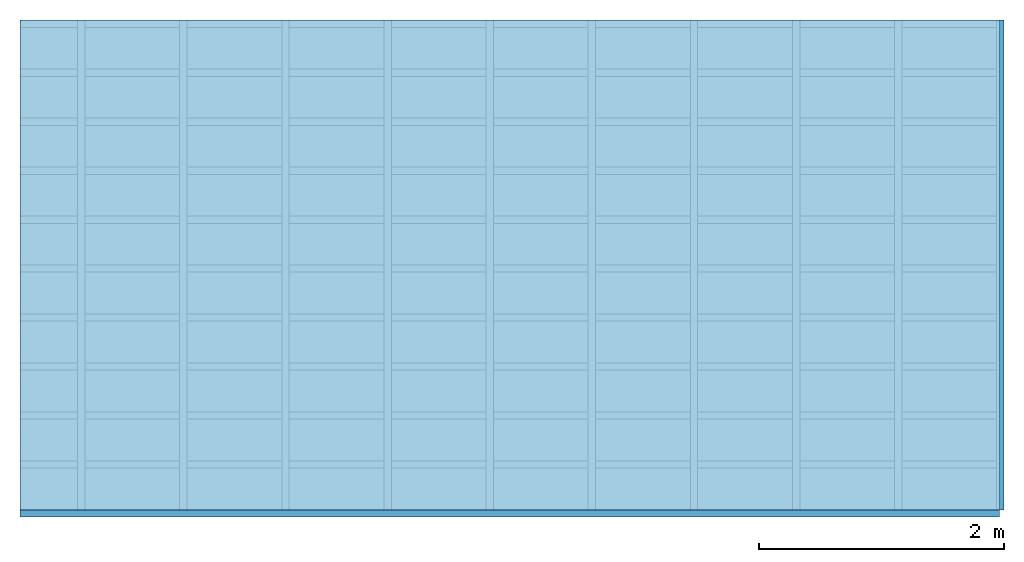
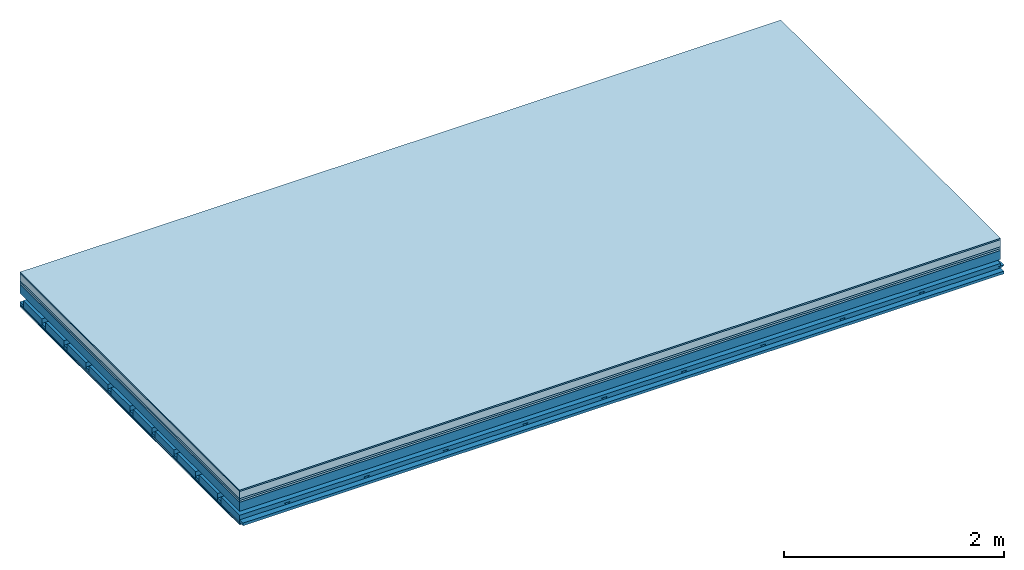
# One storey: 7 plates, 4 members, 1 element without a shape of its own.
"""IFC4 building model written with IfcOpenShell, lengths in metres."""

from ifc_helpers import new_model, si_unit, derived_unit, direction, frame, frame_2d, origin, origin_with_axes, place, context, project, spatial, polyline, rectangle, outline, extrude, material, layer, layer_set, type_object, element, aggregate, save


model = new_model("IFC4")

# Units and contexts
plan_context = context("Plan", 3, precision=1e-05, world=origin(), true_north=direction((0.0, 1.0)))
model_context = context("Model", 3, precision=1e-05, world=origin(), true_north=direction((0.0, 1.0)))
ifc_project = project(units=[si_unit("LENGTHUNIT", "METRE"), derived_unit("SOUNDPRESSUREUNIT", [(si_unit("PRESSUREUNIT", "PASCAL", prefix="MICRO"), 0)]), si_unit("ENERGYUNIT", "JOULE", prefix="MEGA"), si_unit("MASSUNIT", "GRAM", prefix="KILO"), derived_unit("THERMALTRANSMITTANCEUNIT", [(si_unit("POWERUNIT", "WATT"), 1), (si_unit("AREAUNIT", "SQUARE_METRE"), -1), (si_unit("THERMODYNAMICTEMPERATUREUNIT", "KELVIN"), -1)]), derived_unit("AREADENSITYUNIT", [(si_unit("MASSUNIT", "GRAM", prefix="KILO"), 1), (si_unit("AREAUNIT", "SQUARE_METRE"), -1)]), derived_unit("USERDEFINED", [(si_unit("ENERGYUNIT", "JOULE", prefix="MEGA"), 1), (si_unit("AREAUNIT", "SQUARE_METRE"), -1)])], contexts=[plan_context, model_context])

# Site, building, storey
site = spatial("IfcSite", under=ifc_project)
building_placement = place(None, origin())
building = spatial("IfcBuilding", under=site, at=building_placement)
storey_placement = place(building_placement, origin())
storey = spatial("IfcBuildingStorey", under=building, at=storey_placement)

# Slab, members, plates
ifc_material_1 = material(Category="11.013")
ifc_layer_1 = layer(ifc_material_1, 0.015, Name="Flooring")
ifc_material_2 = material(Name="Cement screed", Category="04.006")
ifc_layer_2 = layer(ifc_material_2, 0.08, Name="On-material")
ifc_material_3 = material(Name="Wood fiber generic product", Category="10.009")
ifc_layer_3 = layer(ifc_material_3, 0.02, Name="Impact sound insulation")
ifc_material_4 = material(Category="10.004")
ifc_layer_4 = layer(ifc_material_4, 0.02, Name="Additional insulation")
ifc_material_5 = material(Name="no composite action")
ifc_layer_5 = layer(ifc_material_5, 0.0, Name="Bond")
ifc_layer_6 = layer(None, 0.1, Name="Supporting structure")
ifc_layer_7 = layer(ifc_material_5, 0.0, Name="Bond")
ifc_layer_8 = layer(None, 0.095, Name="Coupling")
ifc_layer_9 = layer(None, 0.03, Name="Battens / profiles")
ifc_material_6 = material(Name="Plasterboard type A", Category="03.008")
ifc_layer_10 = layer(ifc_material_6, 0.0125, Name="Ceiling covering 1st layer")
ifc_layer_11 = layer(ifc_material_6, 0.0125, Name="Ceiling covering layer 2")
ifc_material_7 = material(Category="04.001")
ifc_layer_12 = layer(ifc_material_7, 0.003, Name="Surface / treatment")
ifc_layer_set = layer_set([ifc_layer_1, ifc_layer_2, ifc_layer_3, ifc_layer_4, ifc_layer_5, ifc_layer_6, ifc_layer_7, ifc_layer_8, ifc_layer_9, ifc_layer_10, ifc_layer_11, ifc_layer_12])
slab_type = type_object("IfcSlabType", Name="A2149", PredefinedType="NOTDEFINED", material=ifc_layer_set)
slab_placement = place(None, frame((0.0, 0.0, 0.0), z_axis=(0.0, 0.0, -1.0), x_axis=(1.0, 0.0, 0.0)))
slab = element("IfcSlab", 1, at=slab_placement, inside=storey, type_object=slab_type, material=ifc_layer_set, Name="Slab #1")
ifc_material_8 = material(Name="Solid timber panel")
member_1_placement = place(slab_placement, origin())
member_1 = element("IfcMember", 2, at=member_1_placement, material=ifc_material_8, Name="Supporting structure", context=plan_context, shape_type="SweptSolid", body=[
    extrude(rectangle(XDim=1.0, YDim=0.1, at=frame_2d((0.5, 0.05), x_axis=(1.0, 0.0))), frame((0.0, 4.0, 0.135), z_axis=(0.0, -1.0, 0.0), x_axis=(1.0, 0.0, 0.0)), (0.0, 0.0, 1.0), 4.0),
    extrude(rectangle(XDim=1.0, YDim=0.1, at=frame_2d((0.5, 0.05), x_axis=(1.0, 0.0))), frame((1.0, 4.0, 0.135), z_axis=(0.0, -1.0, 0.0), x_axis=(1.0, 0.0, 0.0)), (0.0, 0.0, 1.0), 4.0),
    extrude(rectangle(XDim=1.0, YDim=0.1, at=frame_2d((0.5, 0.05), x_axis=(1.0, 0.0))), frame((2.0, 4.0, 0.135), z_axis=(0.0, -1.0, 0.0), x_axis=(1.0, 0.0, 0.0)), (0.0, 0.0, 1.0), 4.0),
    extrude(rectangle(XDim=1.0, YDim=0.1, at=frame_2d((0.5, 0.05), x_axis=(1.0, 0.0))), frame((3.0, 4.0, 0.135), z_axis=(0.0, -1.0, 0.0), x_axis=(1.0, 0.0, 0.0)), (0.0, 0.0, 1.0), 4.0),
    extrude(rectangle(XDim=1.0, YDim=0.1, at=frame_2d((0.5, 0.05), x_axis=(1.0, 0.0))), frame((4.0, 4.0, 0.135), z_axis=(0.0, -1.0, 0.0), x_axis=(1.0, 0.0, 0.0)), (0.0, 0.0, 1.0), 4.0),
    extrude(rectangle(XDim=1.0, YDim=0.1, at=frame_2d((0.5, 0.05), x_axis=(1.0, 0.0))), frame((5.0, 4.0, 0.135), z_axis=(0.0, -1.0, 0.0), x_axis=(1.0, 0.0, 0.0)), (0.0, 0.0, 1.0), 4.0),
    extrude(rectangle(XDim=1.0, YDim=0.1, at=frame_2d((0.5, 0.05), x_axis=(1.0, 0.0))), frame((6.0, 4.0, 0.135), z_axis=(0.0, -1.0, 0.0), x_axis=(1.0, 0.0, 0.0)), (0.0, 0.0, 1.0), 4.0),
    extrude(rectangle(XDim=1.0, YDim=0.1, at=frame_2d((0.5, 0.05), x_axis=(1.0, 0.0))), frame((7.0, 4.0, 0.135), z_axis=(0.0, -1.0, 0.0), x_axis=(1.0, 0.0, 0.0)), (0.0, 0.0, 1.0), 4.0),
])
ifc_material_9 = material()
member_2_placement = place(slab_placement, origin())
member_2 = element("IfcMember", 3, at=member_2_placement, material=ifc_material_9, Name="Coupling", context=plan_context, shape_type="SweptSolid", body=[
    extrude(outline(polyline([(0.0, 0.0), (0.06, 0.0), (0.04, 0.02), (0.02, 0.02), (0.0, 0.0)])), frame((0.47, 4.0, 0.31), z_axis=(0.0, -1.0, 0.0), x_axis=(1.0, 0.0, 0.0)), (0.0, 0.0, 1.0), 4.0),
    extrude(outline(polyline([(0.0, 0.0), (0.06, 0.0), (0.04, 0.02), (0.02, 0.02), (0.0, 0.0)])), frame((1.304, 4.0, 0.31), z_axis=(0.0, -1.0, 0.0), x_axis=(1.0, 0.0, 0.0)), (0.0, 0.0, 1.0), 4.0),
    extrude(outline(polyline([(0.0, 0.0), (0.06, 0.0), (0.04, 0.02), (0.02, 0.02), (0.0, 0.0)])), frame((2.138, 4.0, 0.31), z_axis=(0.0, -1.0, 0.0), x_axis=(1.0, 0.0, 0.0)), (0.0, 0.0, 1.0), 4.0),
    extrude(outline(polyline([(0.0, 0.0), (0.06, 0.0), (0.04, 0.02), (0.02, 0.02), (0.0, 0.0)])), frame((2.972, 4.0, 0.31), z_axis=(0.0, -1.0, 0.0), x_axis=(1.0, 0.0, 0.0)), (0.0, 0.0, 1.0), 4.0),
    extrude(outline(polyline([(0.0, 0.0), (0.06, 0.0), (0.04, 0.02), (0.02, 0.02), (0.0, 0.0)])), frame((3.806, 4.0, 0.31), z_axis=(0.0, -1.0, 0.0), x_axis=(1.0, 0.0, 0.0)), (0.0, 0.0, 1.0), 4.0),
    extrude(outline(polyline([(0.0, 0.0), (0.06, 0.0), (0.04, 0.02), (0.02, 0.02), (0.0, 0.0)])), frame((4.64, 4.0, 0.31), z_axis=(0.0, -1.0, 0.0), x_axis=(1.0, 0.0, 0.0)), (0.0, 0.0, 1.0), 4.0),
    extrude(outline(polyline([(0.0, 0.0), (0.06, 0.0), (0.04, 0.02), (0.02, 0.02), (0.0, 0.0)])), frame((5.474, 4.0, 0.31), z_axis=(0.0, -1.0, 0.0), x_axis=(1.0, 0.0, 0.0)), (0.0, 0.0, 1.0), 4.0),
    extrude(outline(polyline([(0.0, 0.0), (0.06, 0.0), (0.04, 0.02), (0.02, 0.02), (0.0, 0.0)])), frame((6.308, 4.0, 0.31), z_axis=(0.0, -1.0, 0.0), x_axis=(1.0, 0.0, 0.0)), (0.0, 0.0, 1.0), 4.0),
    extrude(outline(polyline([(0.0, 0.0), (0.06, 0.0), (0.04, 0.02), (0.02, 0.02), (0.0, 0.0)])), frame((7.142, 4.0, 0.31), z_axis=(0.0, -1.0, 0.0), x_axis=(1.0, 0.0, 0.0)), (0.0, 0.0, 1.0), 4.0),
    extrude(outline(polyline([(0.0, 0.0), (0.06, 0.0), (0.04, 0.02), (0.02, 0.02), (0.0, 0.0)])), frame((7.976, 4.0, 0.31), z_axis=(0.0, -1.0, 0.0), x_axis=(1.0, 0.0, 0.0)), (0.0, 0.0, 1.0), 4.0),
])
member_3_placement = place(slab_placement, origin())
member_3 = element("IfcMember", 4, at=member_3_placement, material=ifc_material_9, Name="Battens / profiles", context=plan_context, shape_type="SweptSolid", body=[
    extrude(rectangle(XDim=0.06, YDim=0.03, at=frame_2d((0.03, 0.015), x_axis=(1.0, 0.0))), frame((0.0, 0.0, 0.33), z_axis=(1.0, 0.0, 0.0), x_axis=(0.0, 1.0, 0.0)), (0.0, 0.0, 1.0), 8.0),
    extrude(rectangle(XDim=0.06, YDim=0.03, at=frame_2d((0.03, 0.015), x_axis=(1.0, 0.0))), frame((0.0, 0.4, 0.33), z_axis=(1.0, 0.0, 0.0), x_axis=(0.0, 1.0, 0.0)), (0.0, 0.0, 1.0), 8.0),
    extrude(rectangle(XDim=0.06, YDim=0.03, at=frame_2d((0.03, 0.015), x_axis=(1.0, 0.0))), frame((0.0, 0.8, 0.33), z_axis=(1.0, 0.0, 0.0), x_axis=(0.0, 1.0, 0.0)), (0.0, 0.0, 1.0), 8.0),
    extrude(rectangle(XDim=0.06, YDim=0.03, at=frame_2d((0.03, 0.015), x_axis=(1.0, 0.0))), frame((0.0, 1.2, 0.33), z_axis=(1.0, 0.0, 0.0), x_axis=(0.0, 1.0, 0.0)), (0.0, 0.0, 1.0), 8.0),
    extrude(rectangle(XDim=0.06, YDim=0.03, at=frame_2d((0.03, 0.015), x_axis=(1.0, 0.0))), frame((0.0, 1.6, 0.33), z_axis=(1.0, 0.0, 0.0), x_axis=(0.0, 1.0, 0.0)), (0.0, 0.0, 1.0), 8.0),
    extrude(rectangle(XDim=0.06, YDim=0.03, at=frame_2d((0.03, 0.015), x_axis=(1.0, 0.0))), frame((0.0, 2.0, 0.33), z_axis=(1.0, 0.0, 0.0), x_axis=(0.0, 1.0, 0.0)), (0.0, 0.0, 1.0), 8.0),
    extrude(rectangle(XDim=0.06, YDim=0.03, at=frame_2d((0.03, 0.015), x_axis=(1.0, 0.0))), frame((0.0, 2.4, 0.33), z_axis=(1.0, 0.0, 0.0), x_axis=(0.0, 1.0, 0.0)), (0.0, 0.0, 1.0), 8.0),
    extrude(rectangle(XDim=0.06, YDim=0.03, at=frame_2d((0.03, 0.015), x_axis=(1.0, 0.0))), frame((0.0, 2.8, 0.33), z_axis=(1.0, 0.0, 0.0), x_axis=(0.0, 1.0, 0.0)), (0.0, 0.0, 1.0), 8.0),
    extrude(rectangle(XDim=0.06, YDim=0.03, at=frame_2d((0.03, 0.015), x_axis=(1.0, 0.0))), frame((0.0, 3.2, 0.33), z_axis=(1.0, 0.0, 0.0), x_axis=(0.0, 1.0, 0.0)), (0.0, 0.0, 1.0), 8.0),
    extrude(rectangle(XDim=0.06, YDim=0.03, at=frame_2d((0.03, 0.015), x_axis=(1.0, 0.0))), frame((0.0, 3.6, 0.33), z_axis=(1.0, 0.0, 0.0), x_axis=(0.0, 1.0, 0.0)), (0.0, 0.0, 1.0), 8.0),
    extrude(rectangle(XDim=0.06, YDim=0.03, at=frame_2d((0.03, 0.015), x_axis=(1.0, 0.0))), frame((0.0, 4.0, 0.33), z_axis=(1.0, 0.0, 0.0), x_axis=(0.0, 1.0, 0.0)), (0.0, 0.0, 1.0), 8.0),
])
ifc_material_10 = material()
member_4_placement = place(slab_placement, origin())
member_4 = element("IfcMember", 5, at=member_4_placement, material=ifc_material_10, Name="Cavity", context=plan_context, shape_type="SweptSolid", body=[
    extrude(rectangle(XDim=0.34, YDim=0.08, at=frame_2d((0.17, 0.04), x_axis=(1.0, 0.0))), frame((0.0, 0.06, 0.28), z_axis=(1.0, 0.0, 0.0), x_axis=(0.0, 1.0, 0.0)), (0.0, 0.0, 1.0), 8.0),
    extrude(rectangle(XDim=0.34, YDim=0.08, at=frame_2d((0.17, 0.04), x_axis=(1.0, 0.0))), frame((0.0, 0.46, 0.28), z_axis=(1.0, 0.0, 0.0), x_axis=(0.0, 1.0, 0.0)), (0.0, 0.0, 1.0), 8.0),
    extrude(rectangle(XDim=0.34, YDim=0.08, at=frame_2d((0.17, 0.04), x_axis=(1.0, 0.0))), frame((0.0, 0.86, 0.28), z_axis=(1.0, 0.0, 0.0), x_axis=(0.0, 1.0, 0.0)), (0.0, 0.0, 1.0), 8.0),
    extrude(rectangle(XDim=0.34, YDim=0.08, at=frame_2d((0.17, 0.04), x_axis=(1.0, 0.0))), frame((0.0, 1.26, 0.28), z_axis=(1.0, 0.0, 0.0), x_axis=(0.0, 1.0, 0.0)), (0.0, 0.0, 1.0), 8.0),
    extrude(rectangle(XDim=0.34, YDim=0.08, at=frame_2d((0.17, 0.04), x_axis=(1.0, 0.0))), frame((0.0, 1.66, 0.28), z_axis=(1.0, 0.0, 0.0), x_axis=(0.0, 1.0, 0.0)), (0.0, 0.0, 1.0), 8.0),
    extrude(rectangle(XDim=0.34, YDim=0.08, at=frame_2d((0.17, 0.04), x_axis=(1.0, 0.0))), frame((0.0, 2.06, 0.28), z_axis=(1.0, 0.0, 0.0), x_axis=(0.0, 1.0, 0.0)), (0.0, 0.0, 1.0), 8.0),
    extrude(rectangle(XDim=0.34, YDim=0.08, at=frame_2d((0.17, 0.04), x_axis=(1.0, 0.0))), frame((0.0, 2.46, 0.28), z_axis=(1.0, 0.0, 0.0), x_axis=(0.0, 1.0, 0.0)), (0.0, 0.0, 1.0), 8.0),
    extrude(rectangle(XDim=0.34, YDim=0.08, at=frame_2d((0.17, 0.04), x_axis=(1.0, 0.0))), frame((0.0, 2.86, 0.28), z_axis=(1.0, 0.0, 0.0), x_axis=(0.0, 1.0, 0.0)), (0.0, 0.0, 1.0), 8.0),
    extrude(rectangle(XDim=0.34, YDim=0.08, at=frame_2d((0.17, 0.04), x_axis=(1.0, 0.0))), frame((0.0, 3.26, 0.28), z_axis=(1.0, 0.0, 0.0), x_axis=(0.0, 1.0, 0.0)), (0.0, 0.0, 1.0), 8.0),
    extrude(rectangle(XDim=0.34, YDim=0.08, at=frame_2d((0.17, 0.04), x_axis=(1.0, 0.0))), frame((0.0, 3.66, 0.28), z_axis=(1.0, 0.0, 0.0), x_axis=(0.0, 1.0, 0.0)), (0.0, 0.0, 1.0), 8.0),
])
plate_1_placement = place(slab_placement, origin())
plate_1 = element("IfcPlate", 6, at=plate_1_placement, material=ifc_material_1, Name="Flooring", context=plan_context, shape_type="SweptSolid", body=[
    extrude(rectangle(XDim=8.0, YDim=4.0, at=frame_2d((4.0, 2.0), x_axis=(1.0, 0.0))), origin_with_axes(), (0.0, 0.0, 1.0), 0.015),
])
plate_2_placement = place(slab_placement, origin())
plate_2 = element("IfcPlate", 7, at=plate_2_placement, material=ifc_material_2, Name="On-material", context=plan_context, shape_type="SweptSolid", body=[
    extrude(rectangle(XDim=8.0, YDim=4.0, at=frame_2d((4.0, 2.0), x_axis=(1.0, 0.0))), frame((0.0, 0.0, 0.015), z_axis=(0.0, 0.0, 1.0), x_axis=(1.0, 0.0, 0.0)), (0.0, 0.0, 1.0), 0.08),
])
plate_3_placement = place(slab_placement, origin())
plate_3 = element("IfcPlate", 8, at=plate_3_placement, material=ifc_material_3, Name="Impact sound insulation", context=plan_context, shape_type="SweptSolid", body=[
    extrude(rectangle(XDim=8.0, YDim=4.0, at=frame_2d((4.0, 2.0), x_axis=(1.0, 0.0))), frame((0.0, 0.0, 0.095), z_axis=(0.0, 0.0, 1.0), x_axis=(1.0, 0.0, 0.0)), (0.0, 0.0, 1.0), 0.02),
])
plate_4_placement = place(slab_placement, origin())
plate_4 = element("IfcPlate", 9, at=plate_4_placement, material=ifc_material_4, Name="Additional insulation", context=plan_context, shape_type="SweptSolid", body=[
    extrude(rectangle(XDim=8.0, YDim=4.0, at=frame_2d((4.0, 2.0), x_axis=(1.0, 0.0))), frame((0.0, 0.0, 0.115), z_axis=(0.0, 0.0, 1.0), x_axis=(1.0, 0.0, 0.0)), (0.0, 0.0, 1.0), 0.02),
])
plate_5_placement = place(slab_placement, origin())
plate_5 = element("IfcPlate", 10, at=plate_5_placement, material=ifc_material_6, Name="Ceiling covering 1st layer", context=plan_context, shape_type="SweptSolid", body=[
    extrude(rectangle(XDim=8.0, YDim=4.0, at=frame_2d((4.0, 2.0), x_axis=(1.0, 0.0))), frame((0.0, 0.0, 0.36), z_axis=(0.0, 0.0, 1.0), x_axis=(1.0, 0.0, 0.0)), (0.0, 0.0, 1.0), 0.0125),
])
plate_6_placement = place(slab_placement, origin())
plate_6 = element("IfcPlate", 11, at=plate_6_placement, material=ifc_material_6, Name="Ceiling covering layer 2", context=plan_context, shape_type="SweptSolid", body=[
    extrude(rectangle(XDim=8.0, YDim=4.0, at=frame_2d((4.0, 2.0), x_axis=(1.0, 0.0))), frame((0.0, 0.0, 0.3725), z_axis=(0.0, 0.0, 1.0), x_axis=(1.0, 0.0, 0.0)), (0.0, 0.0, 1.0), 0.0125),
])
plate_7_placement = place(slab_placement, origin())
plate_7 = element("IfcPlate", 12, at=plate_7_placement, material=ifc_material_7, Name="Surface / treatment", context=plan_context, shape_type="SweptSolid", body=[
    extrude(rectangle(XDim=8.0, YDim=4.0, at=frame_2d((4.0, 2.0), x_axis=(1.0, 0.0))), frame((0.0, 0.0, 0.385), z_axis=(0.0, 0.0, 1.0), x_axis=(1.0, 0.0, 0.0)), (0.0, 0.0, 1.0), 0.003),
])
aggregate(slab, [plate_1, plate_2, plate_3, plate_4, member_1, member_2, member_3, member_4, plate_5, plate_6, plate_7])

save(model, "model.ifc")
